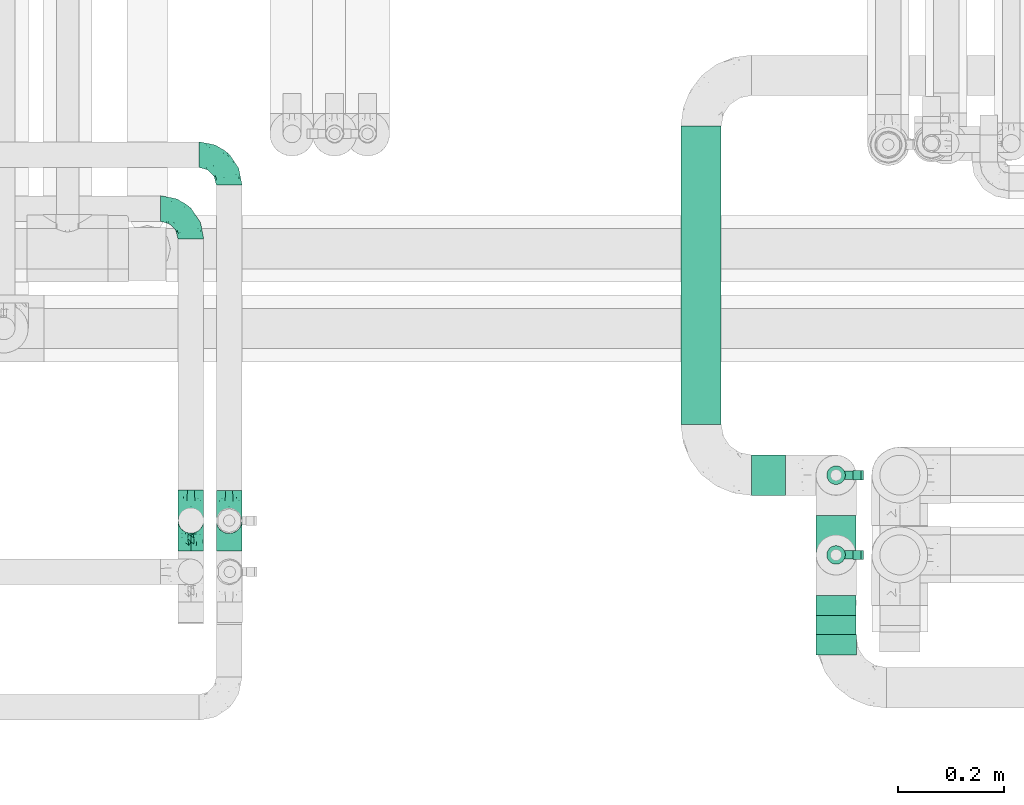
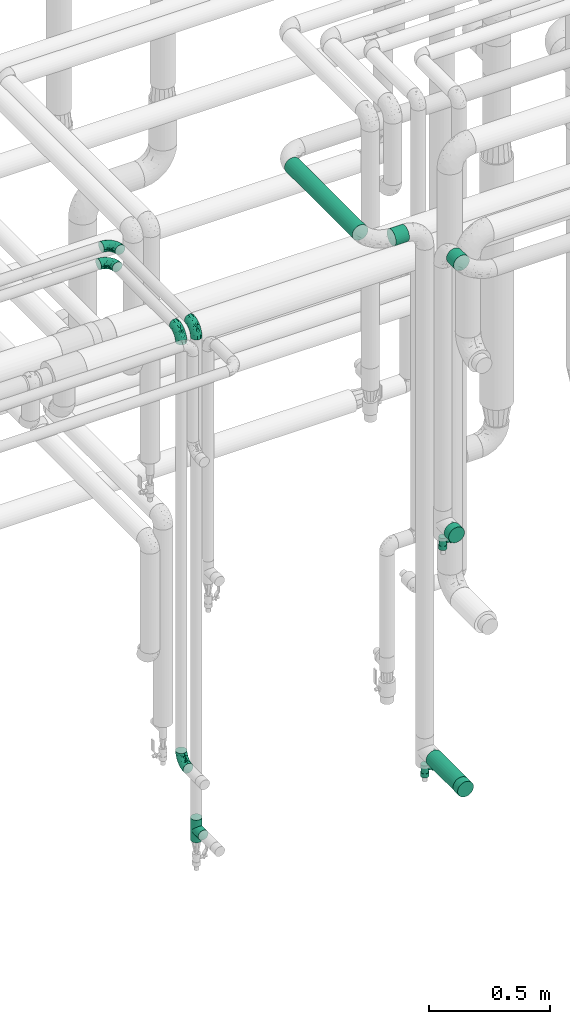
# One storey, part 693 of 827: 8 flow fittings, 4 flow segments, 2 flow controllers.
"""IFC2X3 building model written with IfcOpenShell, lengths in millimetres."""

import ifcopenshell
import ifcopenshell.guid

model = None  # the IFC model being written
_history = None  # IfcOwnerHistory: only IFC2X3 demands one
_inside = {}  # id of a spatial element -> (the spatial element, [elements in it])
_under = {}  # id of a project, library or spatial element -> (it, [spatial elements below it])
_declared = {}  # id of a project -> (the project, [libraries it declares])
_typed = {}  # id of a type object -> (the type object, [elements of that type])
_made_of = {}  # id of a material, layer set ... -> (it, [elements and type objects made of it])


def new_model(schema):
    """Start an empty IFC model of exactly this schema.

    Asked for "IFC4X3", IfcOpenShell would pick the latest addendum, in which some entities
    have other attributes; the version numbers below select the first issue.
    IFC2X3 requires an IfcOwnerHistory on every rooted entity: one is made here for all.
    """
    global model, _history
    if schema == "IFC4X3":
        model = ifcopenshell.file(schema_version=(4, 3, 0, 0))
    else:
        model = ifcopenshell.file(schema=schema)
    _inside.clear()
    _under.clear()
    _declared.clear()
    _typed.clear()
    _made_of.clear()
    _history = None
    if model.schema == "IFC2X3":
        org = make("IfcOrganization", Name="unknown")
        user = make(
            "IfcPersonAndOrganization",
            ThePerson=make("IfcPerson", FamilyName="unknown"),
            TheOrganization=org,
        )
        app = make(
            "IfcApplication",
            ApplicationDeveloper=org,
            Version="unknown",
            ApplicationFullName="unknown",
            ApplicationIdentifier="unknown",
        )
        _history = make(
            "IfcOwnerHistory",
            OwningUser=user,
            OwningApplication=app,
            ChangeAction="ADDED",
            CreationDate=0,
        )
    return model


def make(cls, **values):
    """One entity of the class cls with the attributes given. An attribute that is None is left unset."""
    return model.create_entity(
        cls, **{name: value for name, value in values.items() if value is not None}
    )


def entity(cls, *values):
    """Any entity or typed value of the class cls, its attributes in the order of the schema. None: left unset."""
    e = model.create_entity(cls)
    for i, value in enumerate(values):
        if value is not None:
            e[i] = value
    return e


def rooted(cls, **values):
    """An entity with a GlobalId (a new one), such as an element, a storey or a relation."""
    return make(cls, GlobalId=ifcopenshell.guid.new(), OwnerHistory=_history, **values)


def si_unit(unit_type, name, prefix=None):
    """IfcSIUnit, for example si_unit("LENGTHUNIT", "METRE", prefix="MILLI")."""
    return make("IfcSIUnit", UnitType=unit_type, Prefix=prefix, Name=name)


def converted_unit(unit_type, name, factor, base, dimensions=None, offset=None):
    """IfcConversionBasedUnit, such as the inch: factor (a typed value) times the base unit."""
    return make(
        "IfcConversionBasedUnit"
        if offset is None
        else "IfcConversionBasedUnitWithOffset",
        ConversionOffset=offset,
        Dimensions=None
        if dimensions is None
        else entity("IfcDimensionalExponents", *dimensions),
        UnitType=unit_type,
        Name=name,
        ConversionFactor=make(
            "IfcMeasureWithUnit", ValueComponent=factor, UnitComponent=base
        ),
    )


def derived_unit(unit_type, elements):
    """IfcDerivedUnit: a product of units, each with its exponent."""
    return make(
        "IfcDerivedUnit",
        Elements=[
            make("IfcDerivedUnitElement", Unit=unit, Exponent=power)
            for unit, power in elements
        ],
        UnitType=unit_type,
    )


def assignment(units):
    """IfcUnitAssignment: the units of a project."""
    return None if units is None else make("IfcUnitAssignment", Units=units)


def point(xyz):
    """IfcCartesianPoint."""
    return None if xyz is None else make("IfcCartesianPoint", Coordinates=xyz)


def direction(xyz):
    """IfcDirection."""
    return None if xyz is None else make("IfcDirection", DirectionRatios=xyz)


def frame(location, z_axis=None, x_axis=None):
    """IfcAxis2Placement3D, a coordinate frame: its origin and axes. An axis left out is left unset."""
    return make(
        "IfcAxis2Placement3D",
        Location=point(location),
        Axis=direction(z_axis),
        RefDirection=direction(x_axis),
    )


def frame_2d(location, x_axis=None):
    """IfcAxis2Placement2D, a coordinate frame in the plane: its origin and x axis."""
    return make(
        "IfcAxis2Placement2D", Location=point(location), RefDirection=direction(x_axis)
    )


def origin():
    """The frame at (0, 0, 0) with its axes left unset."""
    return frame((0.0, 0.0, 0.0))


def origin_2d_with_axis():
    """The frame at (0, 0) in the plane with the x axis (1, 0) written out."""
    return frame_2d((0.0, 0.0), x_axis=(1.0, 0.0))


def place(relative_to, where):
    """IfcLocalPlacement: puts the frame where relative to a parent placement (None: the world)."""
    return make(
        "IfcLocalPlacement", PlacementRelTo=relative_to, RelativePlacement=where
    )


def context(
    kind, dimensions, precision=None, world=None, true_north=None, identifier=None
):
    """IfcGeometricRepresentationContext, for example the 3D "Model" context."""
    return make(
        "IfcGeometricRepresentationContext",
        ContextIdentifier=identifier,
        ContextType=kind,
        CoordinateSpaceDimension=dimensions,
        Precision=precision,
        WorldCoordinateSystem=world,
        TrueNorth=true_north,
    )


def subcontext(parent, identifier, kind, view, scale=None):
    """IfcGeometricRepresentationSubContext, for example "Body" below "Model"."""
    return make(
        "IfcGeometricRepresentationSubContext",
        ContextIdentifier=identifier,
        ContextType=kind,
        ParentContext=parent,
        TargetScale=scale,
        TargetView=view,
    )


def project(units=None, contexts=None):
    """IfcProject with its units and contexts."""
    return rooted(
        "IfcProject",
        Name="project",
        RepresentationContexts=contexts,
        UnitsInContext=assignment(units),
    )


def spatial(cls, under=None, at=None, **own):
    """A site, building, storey or space (cls), placed at a placement, below another one or the project."""
    s = rooted(cls, ObjectPlacement=at, **own)
    if under is not None:
        _under.setdefault(under.id(), (under, []))[1].append(s)
    return s


def polyline(points):
    """IfcPolyline through the points."""
    return make("IfcPolyline", Points=[point(p) for p in points])


def profile(cls, at=None, kind="AREA", **sizes):
    """A parametric profile (cls). Its sizes go by their IFC names, for example OverallWidth=200.0."""
    return make(cls, ProfileType=kind, Position=at, **sizes)


def circle(**sizes):
    """IfcCircleProfileDef."""
    return profile("IfcCircleProfileDef", **sizes)


def outline(outer, holes=None, kind="AREA"):
    """IfcArbitraryClosedProfileDef: a profile drawn as a closed curve; with holes, ...WithVoids."""
    if holes is None:
        return make("IfcArbitraryClosedProfileDef", ProfileType=kind, OuterCurve=outer)
    return make(
        "IfcArbitraryProfileDefWithVoids",
        ProfileType=kind,
        OuterCurve=outer,
        InnerCurves=holes,
    )


def extrude(swept, where, along, depth):
    """IfcExtrudedAreaSolid: the profile swept, set in the frame where, extruded along a direction by depth."""
    return make(
        "IfcExtrudedAreaSolid",
        SweptArea=swept,
        Position=where,
        ExtrudedDirection=direction(along),
        Depth=depth,
    )


def faces_of(points, faces, orient=None, outer=None):
    """IfcFace entities. A face is a list of loops; a loop is a list of indices into points, from 0.

    orient and outer hold one flag for each loop. By default every Orientation is true, the
    first loop of a face is its IfcFaceOuterBound and the others are IfcFaceBound.
    """
    made = []
    for i, loops in enumerate(faces):
        bounds = []
        for j, loop in enumerate(loops):
            is_outer = j == 0 if outer is None else outer[i][j]
            bounds.append(
                make(
                    "IfcFaceOuterBound" if is_outer else "IfcFaceBound",
                    Bound=make("IfcPolyLoop", Polygon=[points[k] for k in loop]),
                    Orientation=True if orient is None else orient[i][j],
                )
            )
        made.append(make("IfcFace", Bounds=bounds))
    return made


def faceted_brep(points, faces, orient=None, outer=None, voids=None):
    """IfcFacetedBrep: a solid bounded by flat faces; with voids (closed shells), ...WithVoids."""
    shared = [point(p) for p in points]
    hull = make("IfcClosedShell", CfsFaces=faces_of(shared, faces, orient, outer))
    if voids is None:
        return make("IfcFacetedBrep", Outer=hull)
    return make(
        "IfcFacetedBrepWithVoids",
        Outer=hull,
        Voids=[
            make(cls, CfsFaces=faces_of(shared, fs, o, b)) for cls, fs, o, b in voids
        ],
    )


def shape(context_of_items, identifier, shape_type, items):
    """IfcShapeRepresentation: the items that make up one representation, for example the "Body"."""
    return make(
        "IfcShapeRepresentation",
        ContextOfItems=context_of_items,
        RepresentationIdentifier=identifier,
        RepresentationType=shape_type,
        Items=items,
    )


def source(mapping_origin, context_of_items, identifier, shape_type, items):
    """IfcRepresentationMap: a shape defined once, which mapped items show again and again."""
    return make(
        "IfcRepresentationMap",
        MappingOrigin=mapping_origin,
        MappedRepresentation=shape(context_of_items, identifier, shape_type, items),
    )


def transform(
    local_origin,
    x_axis=None,
    y_axis=None,
    z_axis=None,
    scale=None,
    scale2=None,
    scale3=None,
    uniform=True,
):
    """IfcCartesianTransformationOperator3D, or its non-uniform kind. x_axis, y_axis, z_axis: its Axis1, 2, 3."""
    if uniform:
        return make(
            "IfcCartesianTransformationOperator3D",
            Axis1=direction(x_axis),
            Axis2=direction(y_axis),
            LocalOrigin=point(local_origin),
            Scale=scale,
            Axis3=direction(z_axis),
        )
    return make(
        "IfcCartesianTransformationOperator3DnonUniform",
        Axis1=direction(x_axis),
        Axis2=direction(y_axis),
        LocalOrigin=point(local_origin),
        Scale=scale,
        Axis3=direction(z_axis),
        Scale2=scale2,
        Scale3=scale3,
    )


def mapped(mapping_source, mapping_target):
    """IfcMappedItem: shows the shape of a source again, moved by a transform."""
    return make(
        "IfcMappedItem", MappingSource=mapping_source, MappingTarget=mapping_target
    )


def material(Name=None, Category=None):
    """IfcMaterial."""
    return make("IfcMaterial", Name=Name, Category=Category)


def material_list(materials):
    """IfcMaterialList."""
    return make("IfcMaterialList", Materials=materials)


def made_of(thing, what):
    """Note that an element or type object is made of a material, layer set ...; save() writes the relation."""
    if what is not None:
        _made_of.setdefault(what.id(), (what, []))[1].append(thing)
    return thing


def type_object(cls, material=None, **own):
    """A type object (cls), such as IfcWallType, which elements share."""
    return made_of(rooted(cls, **own), material)


def type_shapes(of_type, sources):
    """Give a type object the sources (RepresentationMaps) that its elements show as mapped items."""
    of_type.RepresentationMaps = sources


def element(
    cls,
    number,
    at=None,
    inside=None,
    cuts=None,
    type_object=None,
    material=None,
    context=None,
    identifier="Body",
    shape_type=None,
    held_by="IfcProductDefinitionShape",
    body=None,
    shapes=None,
    **own,
):
    """One element of the class cls, such as IfcWall. Its Tag is "e" and its number.

    at: its placement. inside: the storey or other place that contains it. cuts: it is an
    opening in that element (IfcRelVoidsElement). A single representation is given by context,
    identifier, shape_type and body (its items); several are given by shapes. held_by: the class
    of the entity that holds the representations. save() writes the other relations.
    """
    e = rooted(cls, Tag="e%d" % number, ObjectPlacement=at, **own)
    if body is not None:
        shapes = [shape(context, identifier, shape_type, body)]
    if shapes is not None:
        e.Representation = make(held_by, Representations=shapes)
    if inside is not None:
        _inside.setdefault(inside.id(), (inside, []))[1].append(e)
    if cuts is not None:
        rooted(
            "IfcRelVoidsElement", RelatingBuildingElement=cuts, RelatedOpeningElement=e
        )
    if type_object is not None:
        _typed.setdefault(type_object.id(), (type_object, []))[1].append(e)
    return made_of(e, material)


def aggregate(whole, parts):
    """IfcRelAggregates: a whole, such as a stair, and the parts it consists of."""
    return rooted("IfcRelAggregates", RelatingObject=whole, RelatedObjects=parts)


def save(model, path):
    """Write the relations noted so far, then the file.

    IfcRelAggregates (storeys below a building ...), IfcRelContainedInSpatialStructure (elements
    in a storey), IfcRelDefinesByType, IfcRelAssociatesMaterial and IfcRelDeclares: one each for
    every whole, place, type object, material and project.
    """
    for whole, parts in _under.values():
        aggregate(whole, parts)
    for where, things in _inside.values():
        rooted(
            "IfcRelContainedInSpatialStructure",
            RelatedElements=things,
            RelatingStructure=where,
        )
    for kind, things in _typed.values():
        rooted("IfcRelDefinesByType", RelatedObjects=things, RelatingType=kind)
    for what, things in _made_of.values():
        rooted("IfcRelAssociatesMaterial", RelatedObjects=things, RelatingMaterial=what)
    for by, libraries in _declared.values():
        rooted("IfcRelDeclares", RelatingContext=by, RelatedDefinitions=libraries)
    model.write(path)


model = new_model("IFC2X3")

# Units and contexts
model_context = context("Model", 3, precision=0.01, world=origin(), true_north=direction((6.12303176911189e-17, 1.0)))
body_context = subcontext(model_context, "Body", "Model", "MODEL_VIEW")
ifc_project = project(units=[si_unit("LENGTHUNIT", "METRE", prefix="MILLI"), si_unit("AREAUNIT", "SQUARE_METRE"), si_unit("VOLUMEUNIT", "CUBIC_METRE"), converted_unit("PLANEANGLEUNIT", "DEGREE", entity("IfcRatioMeasure", 0.0174532925199433), si_unit("PLANEANGLEUNIT", "RADIAN"), dimensions=[0, 0, 0, 0, 0, 0, 0]), si_unit("MASSUNIT", "GRAM", prefix="KILO"), derived_unit("MASSDENSITYUNIT", [(si_unit("MASSUNIT", "GRAM", prefix="KILO"), 1), (si_unit("LENGTHUNIT", "METRE"), -3)]), derived_unit("MOMENTOFINERTIAUNIT", [(si_unit("LENGTHUNIT", "METRE"), 4)]), si_unit("TIMEUNIT", "SECOND"), si_unit("FREQUENCYUNIT", "HERTZ"), si_unit("THERMODYNAMICTEMPERATUREUNIT", "DEGREE_CELSIUS"), derived_unit("THERMALTRANSMITTANCEUNIT", [(si_unit("MASSUNIT", "GRAM", prefix="KILO"), 1), (si_unit("THERMODYNAMICTEMPERATUREUNIT", "KELVIN"), -1), (si_unit("TIMEUNIT", "SECOND"), -3)]), derived_unit("VOLUMETRICFLOWRATEUNIT", [(si_unit("LENGTHUNIT", "METRE"), 3), (si_unit("TIMEUNIT", "SECOND"), -1)]), derived_unit("MASSFLOWRATEUNIT", [(si_unit("MASSUNIT", "GRAM", prefix="KILO"), 1), (si_unit("TIMEUNIT", "SECOND"), -1)]), derived_unit("ROTATIONALFREQUENCYUNIT", [(si_unit("TIMEUNIT", "SECOND"), -1)]), si_unit("ELECTRICCURRENTUNIT", "AMPERE"), si_unit("ELECTRICVOLTAGEUNIT", "VOLT"), si_unit("POWERUNIT", "WATT"), si_unit("FORCEUNIT", "NEWTON", prefix="KILO"), si_unit("ILLUMINANCEUNIT", "LUX"), si_unit("LUMINOUSFLUXUNIT", "LUMEN"), si_unit("LUMINOUSINTENSITYUNIT", "CANDELA"), derived_unit("USERDEFINED", [(si_unit("MASSUNIT", "GRAM", prefix="KILO"), -1), (si_unit("LENGTHUNIT", "METRE"), -2), (si_unit("TIMEUNIT", "SECOND"), 3), (si_unit("LUMINOUSFLUXUNIT", "LUMEN"), 1)]), derived_unit("LINEARVELOCITYUNIT", [(si_unit("LENGTHUNIT", "METRE"), 1), (si_unit("TIMEUNIT", "SECOND"), -1)]), si_unit("PRESSUREUNIT", "PASCAL"), derived_unit("USERDEFINED", [(si_unit("LENGTHUNIT", "METRE"), -2), (si_unit("MASSUNIT", "GRAM", prefix="KILO"), 1), (si_unit("TIMEUNIT", "SECOND"), -2)]), derived_unit("LINEARFORCEUNIT", [(si_unit("MASSUNIT", "GRAM", prefix="KILO"), 1), (si_unit("LENGTHUNIT", "METRE"), 1), (si_unit("TIMEUNIT", "SECOND"), -2), (si_unit("LENGTHUNIT", "METRE"), -1)]), derived_unit("PLANARFORCEUNIT", [(si_unit("MASSUNIT", "GRAM", prefix="KILO"), 1), (si_unit("LENGTHUNIT", "METRE"), 1), (si_unit("TIMEUNIT", "SECOND"), -2), (si_unit("LENGTHUNIT", "METRE"), -2)])], contexts=[model_context])

# Site, building, storey
site_placement = place(None, origin())
site = spatial("IfcSite", under=ifc_project, at=site_placement, CompositionType="ELEMENT")
building_placement = place(site_placement, origin())
building = spatial("IfcBuilding", under=site, at=building_placement, CompositionType="ELEMENT")
storey_placement = place(building_placement, frame((0.0, 0.0, 28200.0)))
storey = spatial("IfcBuildingStorey", under=building, at=storey_placement, Name="08", CompositionType="ELEMENT", Elevation=28200.0)

# Flow segments
pipe_segment_type = type_object("IfcPipeSegmentType", PredefinedType="NOTDEFINED")
flow_segment_1_placement = place(storey_placement, frame((55596.5, 15341.2, 3010.65)))
element("IfcFlowSegment", 1, at=flow_segment_1_placement, inside=storey, type_object=pipe_segment_type, context=body_context, shape_type="SweptSolid", body=[
    extrude(circle(Radius=37.75, at=origin_2d_with_axis()), frame((39.35, 0.0, 39.35), z_axis=(0.0, 1.0, 0.0), x_axis=(1.0, 0.0, 0.0)), (0.0, 0.0, 1.0), 59.9999999999734),
])
flow_segment_2_placement = place(storey_placement, frame((55342.5, 15741.2, 3010.65)))
element("IfcFlowSegment", 2, at=flow_segment_2_placement, inside=storey, type_object=pipe_segment_type, context=body_context, shape_type="SweptSolid", body=[
    extrude(circle(Radius=37.75, at=origin_2d_with_axis()), frame((39.35, 0.0, 39.35), z_axis=(0.0, 1.0, 0.0), x_axis=(1.0, 0.0, 0.0)), (0.0, 0.0, 1.0), 562.412320000007),
])
flow_segment_3_placement = place(storey_placement, frame((55596.5, 15346.2, 369.15)))
element("IfcFlowSegment", 3, at=flow_segment_3_placement, inside=storey, type_object=pipe_segment_type, context=body_context, shape_type="SweptSolid", body=[
    extrude(circle(Radius=37.75, at=origin_2d_with_axis()), frame((39.35, 0.0, 39.35), z_axis=(0.0, 1.0, 0.0), x_axis=(-1.0, 0.0, 0.0)), (0.0, 0.0, 1.0), 224.000000000001),
])
flow_segment_4_placement = place(storey_placement, frame((55476.84, 15606.86, 3010.65)))
element("IfcFlowSegment", 4, at=flow_segment_4_placement, inside=storey, type_object=pipe_segment_type, context=body_context, shape_type="SweptSolid", body=[
    extrude(circle(Radius=37.75, at=origin_2d_with_axis()), frame((0.0, 39.35, 39.35), z_axis=(1.0, 0.0, 0.0), x_axis=(0.0, 1.0, 0.0)), (0.0, 0.0, 1.0), 63.998921802595),
])

# Flow controllers
ifc_material = material()
ifc_material_list = material_list([ifc_material, ifc_material, ifc_material, ifc_material, ifc_material])
valve_type = type_object("IfcValveType", PredefinedType="NOTDEFINED", material=ifc_material_list)
shared_shape_1 = source(origin(), body_context, "Body", "SweptSolid", [
    extrude(circle(Radius=17.5, at=origin_2d_with_axis()), frame((-30.5, 0.0, 0.0), z_axis=(1.0, 0.0, 0.0), x_axis=(0.0, 1.0, 0.0)), (0.0, 0.0, 1.0), 20.3333333333333),
    extrude(circle(Radius=16.0, at=origin_2d_with_axis()), frame((-10.17, 0.0, 0.0), z_axis=(1.0, 0.0, 0.0), x_axis=(0.0, 1.0, 0.0)), (0.0, 0.0, 1.0), 20.3333333333333),
    extrude(circle(Radius=17.5, at=origin_2d_with_axis()), frame((10.17, 0.0, 0.0), z_axis=(1.0, 0.0, 0.0), x_axis=(0.0, 1.0, 0.0)), (0.0, 0.0, 1.0), 20.3333333333333),
    extrude(outline(polyline([(-38.75, -5.0), (-38.75, -10.0), (-17.92, -10.0), (2.08, 5.0), (56.25, 5.0), (56.25, 10.0), (0.42, 10.0), (-19.58, -5.0), (-38.75, -5.0)])), frame((28.75, -8.75, 41.5), z_axis=(0.0, -1.0, 0.0), x_axis=(1.0, 0.0, 0.0)), (0.0, 0.0, -1.0), 17.5),
    extrude(circle(Radius=8.0, at=origin_2d_with_axis()), origin(), (0.0, 0.0, 1.0), 49.0),
])
type_shapes(valve_type, [shared_shape_1])
for number, where, z_axis, x_axis in (
    (5, (55635.84, 15646.2, 302.0), (1.0, 0.0, 0.0), (0.0, 0.0, 1.0)),
    (6, (55635.84, 15496.2, 1543.0), (1.0, 0.0, 0.0), (0.0, 0.0, 1.0)),
):
    element("IfcFlowController", number, at=place(storey_placement, frame(where, z_axis=z_axis, x_axis=x_axis)), inside=storey, type_object=valve_type, material=ifc_material, context=body_context, shape_type="MappedRepresentation", body=[
        mapped(shared_shape_1, transform((0.0, 0.0, 0.0), scale=1.0)),
    ])

# Flow fittings
pipe_fitting_type_1 = type_object("IfcPipeFittingType", Name="ADSK_1", PredefinedType="NOTDEFINED", material=ifc_material)
shared_shape_2 = source(origin(), body_context, "Body", "SweptSolid", [
    extrude(circle(Radius=38.05, at=origin_2d_with_axis()), frame((0.0, 0.0, 0.0), z_axis=(1.0, 0.0, 0.0), x_axis=(0.0, 1.0, 0.0)), (0.0, 0.0, 1.0), 38.0000000000003),
])
type_shapes(pipe_fitting_type_1, [shared_shape_2])
for number, where, z_axis, x_axis, name in (
    (7, (55635.84, 15346.2, 408.5), (0.0, 0.0, 1.0), (0.0, -1.0, 0.0), "ADSK_1"),
    (8, (55635.84, 15420.2, 1649.5), (1.0, 0.0, 0.0), (0.0, -1.0, 0.0), "ADSK_1"),
):
    element("IfcFlowFitting", number, at=place(storey_placement, frame(where, z_axis=z_axis, x_axis=x_axis)), inside=storey, type_object=pipe_fitting_type_1, material=ifc_material, Name=name, ObjectType="ADSK_1", context=body_context, shape_type="MappedRepresentation", body=[
        mapped(shared_shape_2, transform((0.0, 0.0, 0.0), scale=1.0)),
    ])
pipe_fitting_type_2 = type_object("IfcPipeFittingType", Name="ADSK_1", PredefinedType="NOTDEFINED", material=ifc_material)
shared_shape_3 = source(origin(), body_context, "Body", "Brep", [
    faceted_brep([(-57.0, 12.07, -20.91), (-57.0, 6.25, -23.33), (-57.0, 0.0, -24.15), (-57.0, -6.25, -23.33), (-57.0, -12.08, -20.91), (-57.0, -17.08, -17.08), (-57.0, -20.91, -12.08), (-57.0, -23.33, -6.25), (-57.0, -24.15, 0.0), (-57.0, -23.33, 6.25), (-57.0, -20.91, 12.07), (-57.0, -17.08, 17.08), (-57.0, -12.08, 20.91), (-57.0, -6.25, 23.33), (-57.0, 0.0, 24.15), (-57.0, 6.25, 23.33), (-57.0, 12.07, 20.91), (-57.0, 17.08, 17.08), (-57.0, 20.91, 12.07), (-57.0, 23.33, 6.25), (-57.0, 24.15, 0.0), (-57.0, 23.33, -6.25), (-57.0, 20.91, -12.08), (-57.0, 17.08, -17.08), (0.0, 57.0, -24.15), (-6.25, 57.0, -23.33), (-12.07, 57.0, -20.91), (-17.08, 57.0, -17.08), (-20.91, 57.0, -12.08), (-23.33, 57.0, -6.25), (-24.15, 57.0, 0.0), (-23.33, 57.0, 6.25), (-20.91, 57.0, 12.07), (-17.08, 57.0, 17.08), (-12.07, 57.0, 20.91), (-6.25, 57.0, 23.33), (0.0, 57.0, 24.15), (6.25, 57.0, 23.33), (12.08, 57.0, 20.91), (17.08, 57.0, 17.08), (20.91, 57.0, 12.07), (23.33, 57.0, 6.25), (24.15, 57.0, 0.0), (23.33, 57.0, -6.25), (20.91, 57.0, -12.08), (17.08, 57.0, -17.08), (12.08, 57.0, -20.91), (6.25, 57.0, -23.33), (14.9, 21.14, 6.17), (13.61, 24.64, 12.48), (6.23, 8.95, 8.98), (-41.47, -21.06, 0.0), (-41.92, -18.38, 13.72), (-24.64, -13.61, 12.48), (-37.37, -13.24, 18.15), (-6.8, -4.93, 8.18), (-21.76, -15.19, 6.22), (-12.78, -9.18, 0.0), (-37.73, -20.51, 7.75), (-7.38, 7.38, 20.24), (-23.37, -4.26, 20.42), (-11.9, -3.19, 15.86), (-42.14, -8.7, 21.82), (13.24, 37.37, 18.15), (9.33, 23.53, 16.85), (4.26, 23.37, 20.42), (2.77, 10.92, 15.55), (-29.46, 0.91, 23.52), (-44.13, 20.56, 15.69), (-39.25, 26.33, 10.88), (-49.02, 22.92, 9.96), (-34.58, 23.87, 17.15), (-15.8, 6.8, 22.81), (-8.67, 20.47, 23.88), (-18.12, 12.9, 24.08), (-48.29, 14.92, 19.65), (-44.06, -2.85, 23.78), (-9.23, 48.95, 22.58), (-3.78, 42.74, 24.07), (-40.34, 4.26, 24.09), (-44.02, 26.14, 5.46), (-44.04, 9.88, 22.74), (-4.95, 16.87, 22.52), (-2.75, 1.43, 12.5), (-25.48, 40.98, 10.71), (20.51, 37.73, 7.75), (18.38, 41.92, 13.72), (8.7, 42.14, 21.82), (-25.95, -17.97, 0.0), (2.85, 44.06, 23.78), (21.06, 41.47, 0.0), (17.97, 25.95, 0.0), (-24.04, -9.27, 17.13), (-33.26, 33.26, 5.86), (-28.55, 40.57, 0.0), (-40.57, 28.55, 0.0), (-25.29, 47.19, 4.06), (-27.01, 31.1, 16.77), (-15.7, 43.95, 19.9), (-20.27, 45.22, 15.61), (-30.53, 31.98, 12.64), (-11.28, 38.33, 22.92), (-9.97, 27.88, 24.09), (-20.15, 30.26, 21.25), (-31.25, 11.75, 23.64), (-28.75, 7.23, 24.15), (-29.53, 18.06, 22.27), (-28.44, 24.21, 20.02), (-37.55, 17.7, 20.26), (-15.88, 29.25, 22.99), (-20.82, 20.82, 23.44), (-0.91, 29.46, 23.52), (-13.5, -7.67, 12.04), (1.49, 1.56, 5.16), (8.86, 10.35, 4.59), (0.38, -0.38, 0.0), (9.18, 12.78, 0.0), (-37.37, -13.24, -18.15), (8.86, 10.35, -4.59), (-45.22, 20.27, -15.61), (-43.95, 15.7, -19.9), (-38.33, 11.28, -22.92), (-48.95, 9.23, -22.58), (-47.19, 25.29, -4.06), (-33.26, 33.26, -5.86), (18.38, 41.92, -13.72), (-30.26, 20.15, -21.25), (2.85, 44.06, -23.78), (-4.26, 40.34, -24.09), (-40.98, 25.48, -10.71), (-41.92, -18.38, -13.72), (9.25, 23.5, -16.92), (4.26, 23.37, -20.42), (13.24, 37.37, -18.15), (-37.73, -20.51, -7.75), (-11.75, 31.25, -23.64), (-7.23, 28.75, -24.15), (-12.9, 18.12, -24.08), (8.7, 42.14, -21.82), (-44.06, -2.85, -23.78), (-6.8, 15.8, -22.81), (-20.47, 8.67, -23.88), (-24.64, -13.61, -12.48), (-42.74, 3.78, -24.07), (-18.06, 29.53, -22.27), (-24.21, 28.44, -20.02), (-27.88, 9.97, -24.09), (-31.1, 27.01, -16.77), (-26.14, 44.02, -5.46), (14.9, 21.14, -6.17), (20.51, 37.73, -7.75), (-9.88, 44.04, -22.74), (-20.56, 44.13, -15.69), (-21.76, -15.19, -6.22), (-13.5, -7.67, -12.04), (-24.14, -9.76, -16.74), (-11.9, -3.19, -15.86), (-14.92, 48.29, -19.65), (-23.37, -4.26, -20.42), (-0.91, 29.46, -23.52), (-26.33, 39.25, -10.88), (-23.87, 34.58, -17.15), (-42.14, -8.7, -21.82), (-22.92, 49.02, -9.96), (13.61, 24.64, -12.48), (-31.98, 30.53, -12.64), (-16.87, 4.95, -22.52), (-17.7, 37.55, -20.26), (-29.25, 15.88, -22.99), (-20.82, 20.82, -23.44), (-29.46, 0.91, -23.52), (-7.38, 7.38, -20.24), (2.77, 10.92, -15.55), (6.23, 8.95, -8.98), (-6.8, -4.93, -8.18), (-2.81, 1.41, -12.54), (1.49, 1.56, -5.16)], [[[0, 1, 2, 3, 4, 5, 6, 7, 8, 9, 10, 11, 12, 13, 14, 15, 16, 17, 18, 19, 20, 21, 22, 23]], [[24, 25, 26, 27, 28, 29, 30, 31, 32, 33, 34, 35, 36, 37, 38, 39, 40, 41, 42, 43, 44, 45, 46, 47]], [[48, 49, 50]], [[9, 8, 51]], [[52, 53, 54]], [[55, 56, 57]], [[10, 58, 52]], [[9, 58, 10]], [[59, 60, 61]], [[54, 12, 11]], [[54, 62, 12]], [[63, 39, 38]], [[64, 65, 66]], [[62, 60, 67]], [[68, 69, 70]], [[71, 69, 68]], [[72, 73, 74]], [[16, 75, 17]], [[13, 76, 14]], [[35, 77, 78]], [[14, 79, 15]], [[17, 68, 18]], [[14, 76, 79]], [[20, 19, 80]], [[70, 19, 18]], [[81, 15, 79]], [[15, 81, 16]], [[73, 72, 82]], [[66, 83, 50]], [[32, 31, 84]], [[85, 86, 49]], [[63, 87, 65]], [[56, 58, 88]], [[36, 89, 37]], [[85, 41, 40]], [[36, 35, 78]], [[90, 41, 85]], [[40, 39, 86]], [[12, 62, 13]], [[86, 85, 40]], [[48, 85, 49]], [[85, 91, 90]], [[87, 38, 37]], [[92, 60, 54]], [[80, 69, 93]], [[93, 94, 95]], [[10, 52, 11]], [[94, 96, 30]], [[97, 98, 99]], [[80, 93, 95]], [[100, 97, 84]], [[99, 98, 33]], [[101, 102, 78]], [[103, 101, 98]], [[96, 31, 30]], [[77, 98, 101]], [[77, 35, 34]], [[34, 33, 98]], [[9, 51, 58]], [[87, 63, 38]], [[104, 105, 74]], [[106, 103, 107]], [[106, 81, 104]], [[75, 68, 17]], [[108, 107, 71]], [[33, 32, 99]], [[109, 103, 110]], [[101, 109, 102]], [[89, 78, 111]], [[53, 52, 58]], [[54, 11, 52]], [[60, 62, 54]], [[88, 58, 51]], [[76, 62, 67]], [[53, 112, 92]], [[60, 59, 72]], [[39, 63, 86]], [[49, 86, 63]], [[89, 87, 37]], [[42, 41, 90]], [[111, 82, 65]], [[111, 65, 87]], [[65, 59, 66]], [[104, 81, 79]], [[75, 81, 108]], [[32, 84, 99]], [[97, 99, 84]], [[98, 97, 103]], [[106, 107, 108]], [[74, 102, 110]], [[111, 78, 102]], [[74, 110, 104]], [[74, 67, 72]], [[61, 92, 112]], [[66, 59, 61]], [[56, 53, 58]], [[66, 50, 49]], [[61, 112, 83]], [[66, 49, 64]], [[78, 89, 36]], [[87, 89, 111]], [[62, 76, 13]], [[79, 76, 67]], [[100, 93, 69]], [[96, 93, 84]], [[55, 113, 50]], [[113, 114, 50]], [[104, 79, 105]], [[106, 104, 110]], [[20, 80, 95]], [[85, 48, 91]], [[115, 114, 113]], [[116, 91, 48]], [[70, 80, 19]], [[93, 96, 94]], [[84, 31, 96]], [[103, 106, 110]], [[81, 106, 108]], [[103, 97, 107]], [[71, 107, 97]], [[71, 97, 100]], [[108, 71, 68]], [[79, 67, 105]], [[67, 74, 105]], [[115, 113, 57]], [[112, 56, 55]], [[56, 88, 57]], [[60, 72, 67]], [[82, 72, 59]], [[65, 82, 59]], [[82, 111, 73]], [[111, 102, 73]], [[102, 74, 73]], [[81, 75, 16]], [[68, 75, 108]], [[68, 70, 18]], [[80, 70, 69]], [[98, 77, 34]], [[78, 77, 101]], [[93, 100, 84]], [[71, 100, 69]], [[102, 109, 110]], [[101, 103, 109]], [[53, 92, 54]], [[61, 60, 92]], [[56, 112, 53]], [[83, 112, 55]], [[50, 83, 55]], [[61, 83, 66]], [[49, 63, 64]], [[65, 64, 63]], [[57, 113, 55]], [[114, 115, 116]], [[116, 48, 114]], [[48, 50, 114]], [[117, 5, 4]], [[116, 115, 118]], [[119, 120, 23]], [[121, 122, 120]], [[95, 123, 20]], [[0, 23, 120]], [[124, 95, 94]], [[125, 45, 44]], [[121, 120, 126]], [[24, 127, 128]], [[22, 21, 129]], [[0, 122, 1]], [[5, 117, 130]], [[131, 132, 133]], [[134, 88, 51]], [[135, 136, 137]], [[6, 5, 130]], [[46, 138, 47]], [[139, 3, 2]], [[140, 141, 137]], [[6, 134, 7]], [[134, 130, 142]], [[143, 2, 1]], [[144, 126, 145]], [[121, 146, 143]], [[147, 120, 119]], [[94, 148, 124]], [[149, 150, 91]], [[30, 29, 148]], [[151, 25, 128]], [[27, 152, 28]], [[134, 153, 88]], [[154, 155, 156]], [[27, 26, 157]], [[151, 26, 25]], [[155, 158, 156]], [[24, 47, 127]], [[1, 122, 143]], [[138, 132, 159]], [[160, 152, 161]], [[24, 128, 25]], [[46, 133, 138]], [[162, 117, 4]], [[148, 160, 124]], [[152, 160, 163]], [[154, 142, 155]], [[45, 125, 133]], [[133, 46, 45]], [[125, 164, 133]], [[51, 7, 134]], [[42, 90, 43]], [[165, 147, 129]], [[153, 134, 142]], [[43, 150, 44]], [[162, 4, 3]], [[141, 140, 166]], [[117, 162, 158]], [[163, 29, 28]], [[43, 90, 150]], [[123, 21, 20]], [[144, 151, 135]], [[157, 152, 27]], [[167, 145, 161]], [[23, 22, 119]], [[168, 126, 169]], [[121, 168, 146]], [[139, 143, 170]], [[142, 130, 117]], [[8, 7, 51]], [[134, 6, 130]], [[139, 162, 3]], [[170, 166, 158]], [[170, 158, 162]], [[158, 171, 156]], [[44, 150, 125]], [[91, 150, 90]], [[164, 125, 150]], [[132, 138, 133]], [[127, 138, 159]], [[131, 164, 172]], [[132, 171, 140]], [[135, 151, 128]], [[157, 151, 167]], [[22, 129, 119]], [[147, 119, 129]], [[120, 147, 126]], [[144, 145, 167]], [[137, 146, 169]], [[170, 143, 146]], [[137, 169, 135]], [[137, 159, 140]], [[171, 172, 156]], [[173, 174, 175]], [[156, 175, 154]], [[174, 57, 153]], [[132, 172, 171]], [[172, 164, 173]], [[143, 139, 2]], [[162, 139, 170]], [[138, 127, 47]], [[128, 127, 159]], [[165, 124, 160]], [[123, 124, 129]], [[149, 173, 164]], [[176, 174, 173]], [[135, 128, 136]], [[144, 135, 169]], [[150, 149, 164]], [[176, 118, 115]], [[149, 91, 116]], [[30, 148, 94]], [[163, 148, 29]], [[124, 123, 95]], [[129, 21, 123]], [[126, 144, 169]], [[151, 144, 167]], [[126, 147, 145]], [[161, 145, 147]], [[161, 147, 165]], [[167, 161, 152]], [[128, 159, 136]], [[159, 137, 136]], [[154, 153, 142]], [[132, 140, 159]], [[174, 176, 57]], [[57, 88, 153]], [[166, 140, 171]], [[158, 166, 171]], [[166, 170, 141]], [[170, 146, 141]], [[146, 137, 141]], [[151, 157, 26]], [[152, 157, 167]], [[152, 163, 28]], [[148, 163, 160]], [[120, 122, 0]], [[143, 122, 121]], [[124, 165, 129]], [[161, 165, 160]], [[146, 168, 169]], [[121, 126, 168]], [[142, 117, 155]], [[158, 155, 117]], [[175, 156, 172]], [[153, 154, 174]], [[173, 175, 172]], [[174, 154, 175]], [[164, 131, 133]], [[172, 132, 131]], [[176, 173, 118]], [[57, 176, 115]], [[173, 149, 118]], [[149, 116, 118]]]),
])
type_shapes(pipe_fitting_type_2, [shared_shape_3])
for number, where, z_axis, x_axis, name in (
    (9, (54493.91, 15560.75, 3000.0), (1.0, 0.0, 0.0), (0.0, -1.0, 0.0), "ADSK_1"),
    (10, (54421.88, 15561.03, 820.0), (-1.0, 0.0, 0.0), (0.0, 0.0, -1.0), "ADSK_1"),
    (11, (54421.88, 16147.94, 3000.0), (0.0, 0.0, 1.0), (0.0, 1.0, 0.0), "ADSK_1"),
    (12, (54421.88, 15561.03, 3000.0), (-1.0, 0.0, 0.0), (0.0, 0.0, 1.0), "ADSK_1"),
    (13, (54493.91, 16249.47, 3000.0), (0.0, 0.0, 1.0), (0.0, 1.0, 0.0), "ADSK_1"),
):
    element("IfcFlowFitting", number, at=place(storey_placement, frame(where, z_axis=z_axis, x_axis=x_axis)), inside=storey, type_object=pipe_fitting_type_2, material=ifc_material, Name=name, ObjectType="ADSK_1", context=body_context, shape_type="MappedRepresentation", body=[
        mapped(shared_shape_3, transform((0.0, 0.0, 0.0), scale=1.0)),
    ])
pipe_fitting_type_3 = type_object("IfcPipeFittingType", Name="ADSK_1", PredefinedType="NOTDEFINED", material=ifc_material)
shared_shape_4 = source(origin(), body_context, "Body", "Brep", [
    faceted_brep([(-57.0, 12.07, -20.91), (-57.0, 6.25, -23.33), (-57.0, 0.0, -24.15), (-57.0, -6.25, -23.33), (-57.0, -12.08, -20.91), (-57.0, -17.08, -17.08), (-57.0, -20.91, -12.08), (-57.0, -23.33, -6.25), (-57.0, -24.15, 0.0), (-57.0, -23.33, 6.25), (-57.0, -20.91, 12.07), (-57.0, -17.08, 17.08), (-57.0, -12.08, 20.91), (-57.0, -6.25, 23.33), (-57.0, 0.0, 24.15), (-57.0, 6.25, 23.33), (-57.0, 12.07, 20.91), (-57.0, 17.08, 17.08), (-57.0, 20.91, 12.07), (-57.0, 23.33, 6.25), (-57.0, 24.15, 0.0), (-57.0, 23.33, -6.25), (-57.0, 20.91, -12.08), (-57.0, 17.08, -17.08), (57.0, 0.0, -24.15), (57.0, 6.25, -23.33), (57.0, 12.07, -20.91), (57.0, 17.08, -17.08), (57.0, 20.91, -12.08), (57.0, 23.33, -6.25), (57.0, 24.15, 0.0), (57.0, 23.33, 6.25), (57.0, 20.91, 12.07), (57.0, 17.08, 17.08), (57.0, 12.07, 20.91), (57.0, 6.25, 23.33), (57.0, 0.0, 24.15), (57.0, -6.25, 23.33), (57.0, -12.08, 20.91), (57.0, -17.08, 17.08), (57.0, -20.91, 12.07), (57.0, -23.33, 6.25), (57.0, -24.15, 0.0), (57.0, -23.33, -6.25), (57.0, -20.91, -12.08), (57.0, -17.08, -17.08), (57.0, -12.08, -20.91), (57.0, -6.25, -23.33), (23.27, -23.27, 6.45), (24.15, -24.15, 0.0), (-24.15, -24.15, 0.0), (20.9, -20.9, 12.1), (13.54, -13.54, 20.0), (17.52, -17.52, 16.62), (-23.27, -23.27, 6.45), (-20.9, -20.9, 12.1), (-17.52, -17.52, 16.62), (-13.54, -13.54, 20.0), (-9.19, -9.19, 22.33), (9.19, -9.19, 22.33), (4.64, -4.64, 23.7), (0.0, 0.0, 24.15), (-4.64, -4.64, 23.7), (4.64, -4.64, -23.7), (0.0, 0.0, -24.15), (-4.64, -4.64, -23.7), (-9.19, -9.19, -22.33), (9.19, -9.19, -22.33), (13.54, -13.54, -20.0), (17.52, -17.52, -16.62), (20.9, -20.9, -12.1), (23.27, -23.27, -6.45), (-13.54, -13.54, -20.0), (-17.52, -17.52, -16.62), (-23.27, -23.27, -6.45), (-20.9, -20.9, -12.1), (0.0, -57.0, -24.15), (6.25, -57.0, -23.33), (12.08, -57.0, -20.91), (17.08, -57.0, -17.08), (20.91, -57.0, -12.08), (23.33, -57.0, -6.25), (24.15, -57.0, 0.0), (23.33, -57.0, 6.25), (20.91, -57.0, 12.07), (17.08, -57.0, 17.08), (12.08, -57.0, 20.91), (6.25, -57.0, 23.33), (0.0, -57.0, 24.15), (-6.25, -57.0, 23.33), (-12.07, -57.0, 20.91), (-17.08, -57.0, 17.08), (-20.91, -57.0, 12.07), (-23.33, -57.0, 6.25), (-24.15, -57.0, 0.0), (-23.33, -57.0, -6.25), (-20.91, -57.0, -12.08), (-17.08, -57.0, -17.08), (-12.07, -57.0, -20.91), (-6.25, -57.0, -23.33)], [[[0, 1, 2, 3, 4, 5, 6, 7, 8, 9, 10, 11, 12, 13, 14, 15, 16, 17, 18, 19, 20, 21, 22, 23]], [[24, 25, 26, 27, 28, 29, 30, 31, 32, 33, 34, 35, 36, 37, 38, 39, 40, 41, 42, 43, 44, 45, 46, 47]], [[41, 40, 48]], [[42, 41, 49]], [[50, 9, 8]], [[49, 41, 48]], [[40, 51, 48]], [[39, 38, 52]], [[51, 40, 53]], [[52, 53, 39]], [[53, 40, 39]], [[50, 54, 9]], [[9, 54, 10]], [[54, 55, 10]], [[56, 57, 11]], [[11, 10, 56]], [[11, 57, 12]], [[56, 10, 55]], [[12, 57, 58]], [[52, 38, 59]], [[60, 36, 61]], [[62, 61, 14]], [[59, 37, 60]], [[37, 59, 38]], [[60, 37, 36]], [[61, 36, 35, 15, 14]], [[32, 31, 19, 18]], [[17, 16, 34, 33]], [[18, 17, 33, 32]], [[35, 34, 16, 15]], [[20, 19, 31, 30]], [[62, 13, 58]], [[13, 62, 14]], [[58, 13, 12]], [[27, 23, 22, 28]], [[22, 21, 29, 28]], [[0, 23, 27, 26]], [[20, 30, 29, 21]], [[24, 47, 63]], [[24, 64, 2, 1, 25]], [[64, 24, 63]], [[2, 64, 65]], [[26, 25, 1, 0]], [[65, 66, 3]], [[2, 65, 3]], [[66, 4, 3]], [[63, 47, 67]], [[46, 45, 68]], [[69, 68, 45]], [[44, 70, 69]], [[69, 45, 44]], [[46, 68, 67]], [[43, 42, 49]], [[7, 50, 8]], [[43, 71, 44]], [[71, 43, 49]], [[44, 71, 70]], [[72, 4, 66]], [[72, 5, 4]], [[5, 72, 73]], [[5, 73, 6]], [[74, 50, 7]], [[75, 74, 6]], [[74, 7, 6]], [[75, 6, 73]], [[46, 67, 47]], [[76, 77, 78, 79, 80, 81, 82, 83, 84, 85, 86, 87, 88, 89, 90, 91, 92, 93, 94, 95, 96, 97, 98, 99]], [[50, 94, 93]], [[54, 50, 93]], [[91, 90, 57]], [[56, 92, 91]], [[54, 93, 92]], [[58, 90, 89]], [[55, 54, 92]], [[56, 55, 92]], [[58, 57, 90]], [[88, 61, 62]], [[58, 89, 62]], [[56, 91, 57]], [[62, 89, 88]], [[60, 88, 87]], [[86, 59, 87]], [[84, 83, 48]], [[53, 85, 84]], [[52, 86, 85]], [[49, 83, 82]], [[59, 60, 87]], [[52, 59, 86]], [[49, 48, 83]], [[51, 53, 84]], [[48, 51, 84]], [[52, 85, 53]], [[88, 60, 61]], [[82, 81, 49]], [[71, 49, 81]], [[69, 80, 79]], [[79, 78, 68]], [[71, 81, 80]], [[67, 78, 77]], [[70, 71, 80]], [[69, 70, 80]], [[67, 68, 78]], [[76, 64, 63]], [[67, 77, 63]], [[69, 79, 68]], [[63, 77, 76]], [[65, 76, 99]], [[98, 66, 99]], [[96, 95, 74]], [[73, 97, 96]], [[72, 98, 97]], [[50, 95, 94]], [[66, 65, 99]], [[72, 66, 98]], [[50, 74, 95]], [[75, 73, 96]], [[74, 75, 96]], [[72, 97, 73]], [[76, 65, 64]]]),
])
type_shapes(pipe_fitting_type_3, [shared_shape_4])
flow_fitting_placement = place(storey_placement, frame((54493.91, 15560.75, 457.5), z_axis=(1.0, 0.0, 0.0), x_axis=(0.0, 0.0, -1.0)))
element("IfcFlowFitting", 14, at=flow_fitting_placement, inside=storey, type_object=pipe_fitting_type_3, material=ifc_material, Name="ADSK_1", ObjectType="ADSK_1", context=body_context, shape_type="MappedRepresentation", body=[
    mapped(shared_shape_4, transform((0.0, 0.0, 0.0), scale=1.0)),
])

save(model, "model.ifc")
